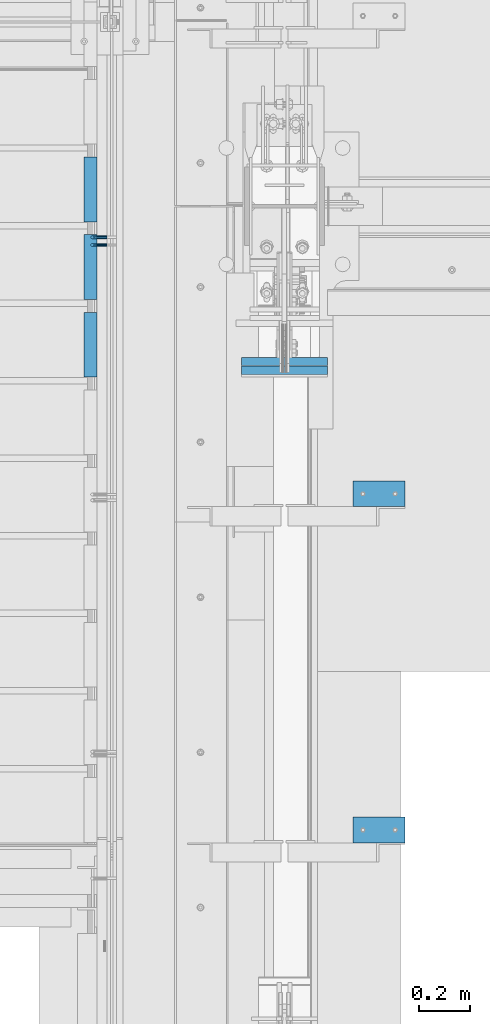
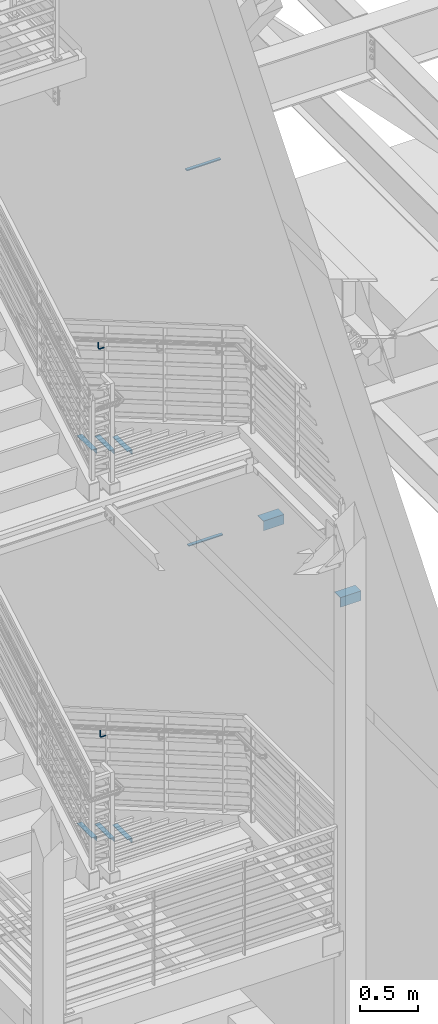
# One storey, part 869 of 1179: 12 beams, 8 elements without a shape of their own.
"""IFC2X3 building model written with IfcOpenShell, lengths in millimetres."""

from ifc_helpers import new_model, si_unit, frame, origin_with_axes, place, context, subcontext, project, spatial, faceted_brep, material, type_object, element, aggregate, save


model = new_model("IFC2X3")

# Units and contexts
model_context = context("Model", 3, precision=1e-05, world=origin_with_axes())
body_context = subcontext(model_context, "Body", "Model", "MODEL_VIEW")
ifc_project = project(units=[si_unit("LENGTHUNIT", "METRE", prefix="MILLI"), si_unit("AREAUNIT", "SQUARE_METRE"), si_unit("VOLUMEUNIT", "CUBIC_METRE"), si_unit("MASSUNIT", "GRAM", prefix="KILO"), si_unit("TIMEUNIT", "SECOND"), si_unit("PLANEANGLEUNIT", "RADIAN"), si_unit("SOLIDANGLEUNIT", "STERADIAN"), si_unit("THERMODYNAMICTEMPERATUREUNIT", "DEGREE_CELSIUS"), si_unit("LUMINOUSINTENSITYUNIT", "LUMEN")], contexts=[model_context])

# Site, building, storey
site_placement = place(None, origin_with_axes())
site = spatial("IfcSite", under=ifc_project, at=site_placement, CompositionType="ELEMENT")
building_placement = place(site_placement, origin_with_axes())
building = spatial("IfcBuilding", under=site, at=building_placement, Name="Undefined", CompositionType="ELEMENT")
storey_placement = place(building_placement, origin_with_axes())
storey = spatial("IfcBuildingStorey", under=building, at=storey_placement, Name="Undefined", CompositionType="ELEMENT", Elevation=0.0)

# Assembly, beams
assembly_1_placement = place(storey_placement, origin_with_axes())
assembly_1 = element("IfcElementAssembly", 1, at=assembly_1_placement, inside=storey, Name="STRINGER", AssemblyPlace="NOTDEFINED", PredefinedType="RIGID_FRAME")
ifc_material_1 = material(Name="STEEL/A36")
beam_type_1 = type_object("IfcBeamType", Name="L2X2X3/16", PredefinedType="NOTDEFINED")
beam_1_placement = place(assembly_1_placement, frame((-330.199999991041, 33974.7356224256, 4867.27499923135), z_axis=(-1.0, 0.0, 0.0), x_axis=(0.0, -1.0, 0.0)))
beam_1 = element("IfcBeam", 2, at=beam_1_placement, type_object=beam_type_1, material=ifc_material_1, Name="ANGLE", ObjectType="L2X2X3/16", context=body_context, shape_type="Brep", body=[
    faceted_brep([(0.0, 25.3999999999996, -25.4000000000015), (0.0, 25.3999999999996, 25.4000000000015), (254.0, 25.3999999999996, 25.4000000000001), (254.0, 25.3999999999996, -25.4000000000001), (0.0, 20.6374999999998, 25.4000000000015), (254.0, 20.6374999999998, 25.4000000000001), (0.0, 20.6374999999998, -20.6374999999971), (254.0, 20.6374999999998, -20.6374999999998), (0.0, -25.3999999999996, -20.6374999999971), (254.0, -25.3999999999996, -20.6374999999998), (0.0, -25.3999999999996, -25.4000000000015), (254.0, -25.3999999999996, -25.4000000000001)], [[[0, 1, 2, 3]], [[1, 4, 5, 2]], [[4, 6, 7, 5]], [[6, 8, 9, 7]], [[8, 10, 11, 9]], [[10, 0, 3, 11]], [[5, 7, 9, 11, 3, 2]], [[10, 8, 6, 4, 1, 0]]]),
])
beam_2_placement = place(assembly_1_placement, frame((-330.199999993097, 34279.5356223616, 4689.47499912165), z_axis=(-1.0, 0.0, 0.0), x_axis=(0.0, -1.0, 0.0)))
beam_2 = element("IfcBeam", 3, at=beam_2_placement, type_object=beam_type_1, material=ifc_material_1, Name="ANGLE", ObjectType="L2X2X3/16", context=body_context, shape_type="Brep", body=[
    faceted_brep([(0.0, 25.3999999999996, -25.4000000000015), (0.0, 25.3999999999996, 25.4000000000015), (254.0, 25.3999999999996, 25.4000000000001), (254.0, 25.3999999999996, -25.4000000000001), (0.0, 20.6374999999998, 25.4000000000015), (254.0, 20.6374999999998, 25.4000000000001), (0.0, 20.6374999999998, -20.6374999999971), (254.0, 20.6374999999998, -20.6374999999998), (0.0, -25.3999999999996, -20.6374999999971), (254.0, -25.3999999999996, -20.6374999999998), (0.0, -25.3999999999996, -25.4000000000015), (254.0, -25.3999999999996, -25.4000000000001)], [[[0, 1, 2, 3]], [[1, 4, 5, 2]], [[4, 6, 7, 5]], [[6, 8, 9, 7]], [[8, 10, 11, 9]], [[10, 0, 3, 11]], [[5, 7, 9, 11, 3, 2]], [[10, 8, 6, 4, 1, 0]]]),
])
beam_3_placement = place(assembly_1_placement, frame((-330.199999995153, 34584.3356222976, 4511.67499901195), z_axis=(-1.0, 0.0, 0.0), x_axis=(0.0, -1.0, 0.0)))
beam_3 = element("IfcBeam", 4, at=beam_3_placement, type_object=beam_type_1, material=ifc_material_1, Name="ANGLE", ObjectType="L2X2X3/16", context=body_context, shape_type="Brep", body=[
    faceted_brep([(0.0, 25.3999999999996, -25.4000000000015), (0.0, 25.3999999999996, 25.4000000000015), (254.0, 25.3999999999996, 25.4000000000001), (254.0, 25.3999999999996, -25.4000000000001), (0.0, 20.6374999999998, 25.4000000000015), (254.0, 20.6374999999998, 25.4000000000001), (0.0, 20.6374999999998, -20.6374999999971), (254.0, 20.6374999999998, -20.6374999999998), (0.0, -25.3999999999996, -20.6374999999971), (254.0, -25.3999999999996, -20.6374999999998), (0.0, -25.3999999999996, -25.4000000000015), (254.0, -25.3999999999996, -25.4000000000001)], [[[0, 1, 2, 3]], [[1, 4, 5, 2]], [[4, 6, 7, 5]], [[6, 8, 9, 7]], [[8, 10, 11, 9]], [[10, 0, 3, 11]], [[5, 7, 9, 11, 3, 2]], [[10, 8, 6, 4, 1, 0]]]),
])
aggregate(assembly_1, [beam_1, beam_2, beam_3])

assembly_2_placement = place(storey_placement, origin_with_axes())
assembly_2 = element("IfcElementAssembly", 5, at=assembly_2_placement, inside=storey, Name="STRINGER", AssemblyPlace="NOTDEFINED", PredefinedType="RIGID_FRAME")
beam_4_placement = place(assembly_2_placement, frame((-330.200000005332, 33974.6819391909, 803.029659879628), z_axis=(-1.0, 0.0, 0.0), x_axis=(0.0, -1.0, 0.0)))
beam_4 = element("IfcBeam", 6, at=beam_4_placement, type_object=beam_type_1, material=ifc_material_1, Name="ANGLE", ObjectType="L2X2X3/16", context=body_context, shape_type="Brep", body=[
    faceted_brep([(0.0, 25.3999999999996, -25.4000000000015), (0.0, 25.3999999999996, 25.4000000000015), (254.0, 25.3999999999996, 25.4000000000001), (254.0, 25.3999999999996, -25.4000000000001), (0.0, 20.6374999999998, 25.4000000000015), (254.0, 20.6374999999998, 25.4000000000001), (0.0, 20.6374999999998, -20.6374999999971), (254.0, 20.6374999999998, -20.6374999999998), (0.0, -25.3999999999996, -20.6374999999971), (254.0, -25.3999999999996, -20.6374999999998), (0.0, -25.3999999999996, -25.4000000000015), (254.0, -25.3999999999996, -25.4000000000001)], [[[0, 1, 2, 3]], [[1, 4, 5, 2]], [[4, 6, 7, 5]], [[6, 8, 9, 7]], [[8, 10, 11, 9]], [[10, 0, 3, 11]], [[5, 7, 9, 11, 3, 2]], [[10, 8, 6, 4, 1, 0]]]),
])
beam_5_placement = place(assembly_2_placement, frame((-330.200000005292, 34279.482092925, 626.547765742485), z_axis=(-1.0, 0.0, 0.0), x_axis=(0.0, -1.0, 0.0)))
beam_5 = element("IfcBeam", 7, at=beam_5_placement, type_object=beam_type_1, material=ifc_material_1, Name="ANGLE", ObjectType="L2X2X3/16", context=body_context, shape_type="Brep", body=[
    faceted_brep([(0.0, 25.3999999999996, -25.4000000000015), (0.0, 25.3999999999996, 25.4000000000015), (254.0, 25.3999999999996, 25.4000000000001), (254.0, 25.3999999999996, -25.4000000000001), (0.0, 20.6374999999998, 25.4000000000015), (254.0, 20.6374999999998, 25.4000000000001), (0.0, 20.6374999999998, -20.6374999999971), (254.0, 20.6374999999998, -20.6374999999998), (0.0, -25.3999999999996, -20.6374999999971), (254.0, -25.3999999999996, -20.6374999999998), (0.0, -25.3999999999996, -25.4000000000015), (254.0, -25.3999999999996, -25.4000000000001)], [[[0, 1, 2, 3]], [[1, 4, 5, 2]], [[4, 6, 7, 5]], [[6, 8, 9, 7]], [[8, 10, 11, 9]], [[10, 0, 3, 11]], [[5, 7, 9, 11, 3, 2]], [[10, 8, 6, 4, 1, 0]]]),
])
beam_6_placement = place(assembly_2_placement, frame((-330.200000005252, 34584.2822466591, 450.065871605343), z_axis=(-1.0, 0.0, 0.0), x_axis=(0.0, -1.0, 0.0)))
beam_6 = element("IfcBeam", 8, at=beam_6_placement, type_object=beam_type_1, material=ifc_material_1, Name="ANGLE", ObjectType="L2X2X3/16", context=body_context, shape_type="Brep", body=[
    faceted_brep([(0.0, 25.3999999999996, -25.4000000000015), (0.0, 25.3999999999996, 25.4000000000015), (254.0, 25.3999999999996, 25.4000000000001), (254.0, 25.3999999999996, -25.4000000000001), (0.0, 20.6374999999998, 25.4000000000015), (254.0, 20.6374999999998, 25.4000000000001), (0.0, 20.6374999999998, -20.6374999999971), (254.0, 20.6374999999998, -20.6374999999998), (0.0, -25.3999999999996, -20.6374999999971), (254.0, -25.3999999999996, -20.6374999999998), (0.0, -25.3999999999996, -25.4000000000015), (254.0, -25.3999999999996, -25.4000000000001)], [[[0, 1, 2, 3]], [[1, 4, 5, 2]], [[4, 6, 7, 5]], [[6, 8, 9, 7]], [[8, 10, 11, 9]], [[10, 0, 3, 11]], [[5, 7, 9, 11, 3, 2]], [[10, 8, 6, 4, 1, 0]]]),
])
aggregate(assembly_2, [beam_4, beam_5, beam_6])

# Assembly, beam
assembly_3_placement = place(storey_placement, origin_with_axes())
assembly_3 = element("IfcElementAssembly", 9, at=assembly_3_placement, inside=storey, Name="GUARDRAIL", AssemblyPlace="NOTDEFINED", PredefinedType="RIGID_FRAME")
beam_type_2 = type_object("IfcBeamType", PredefinedType="NOTDEFINED")
beam_7_placement = place(assembly_3_placement, frame((-266.699999255495, 34269.6796629691, 5619.0742745199), z_axis=(0.0, 0.0, 1.0), x_axis=(-1.0, 0.0, 0.0)))
beam_7 = element("IfcBeam", 10, at=beam_7_placement, type_object=beam_type_2, material=ifc_material_1, Name="BRACKET", context=body_context, shape_type="Brep", body=[
    faceted_brep([(0.0, -4.49012806053361, 4.49012806053452), (0.0, 0.0, 6.34999999999991), (0.0, 4.49012806053361, 4.49012806053452), (0.0, 6.34999999999854, 0.0), (0.0, 4.49012806053361, -4.49012806053452), (0.0, 0.0, -6.34999999999991), (0.0, -4.49012806053361, -4.49012806053452), (0.0, -6.34999999999854, 0.0), (44.4500031699827, 0.0, -6.34999999999991), (44.4500031699827, -4.49012806053361, -4.49012806053452), (44.4500031699827, -6.34999999999854, 2.19733919948339e-09), (44.4500031699827, -4.49012806053361, 4.49012806053452), (44.4500031699827, 0.0, 6.34999999999991), (44.4500031699827, 4.49012806053361, 4.49012806053452), (44.4500031699827, 6.34999999999854, 0.0), (44.4500031699827, 4.49012806053361, -4.49012806053452), (53.0450671075391, 4.4901280570557, -2.18708762112465), (53.97500307462, -4.32919478043914e-09, -3.79778396764459), (53.0450671022344, -4.49012806401151, -2.1870876194389), (50.8000030708674, -6.35000000142099, 1.70147734757802), (48.5549390416977, -4.4901280599006, 5.59004231389645), (47.6250030746168, 1.48793333210051e-09, 7.20073866041594), (48.5549390470023, 4.49012806117025, 5.5900423122107), (50.8000030783693, 6.34999999857973, 1.70147734519378), (55.4485256393576, 6.34999999469437, 6.34999990618098), (59.337090604122, 4.49012805180246, 4.10493587545716), (51.5599606707875, 4.49012805866005, 8.59506393599531), (49.9492643188311, -4.54747350886464e-10, 9.52499990463002), (51.5599606615996, -4.4901280624108, 8.59506393379797), (55.4485256263639, -6.35000000530636, 6.34999990307369), (59.337090594938, -4.49012806926839, 4.10493587326664), (60.9477869468905, -1.0153598850593e-08, 3.17499990462466), (61.6401310450869, 4.49012804462109, 12.6999998130159), (63.5000029792477, -1.81098585017025e-08, 12.6999998092651), (57.1500029867496, 6.3499999893902, 12.6999998145698), (52.6598749240178, 4.49012805522943, 12.6999998130159), (50.8000029792477, -3.10683390125632e-09, 12.6999998092651), (52.6598749134085, -4.49012806583778, 12.6999998055144), (57.1500029739432, -6.35000001061053, 12.6999998039605), (61.6401310344776, -4.49012807644976, 12.6999998055144), (63.5000029792478, -6.94672053214163e-08, 76.1999999999989), (61.6401294880352, -4.49012904147821, 73.5807586715764), (57.1500014109847, -6.35000090467656, 72.4958334126568), (52.6598733669657, -4.49012891602615, 73.5807587357776), (50.8000029792478, -5.78438630327582e-08, 76.1999999999989), (52.6598734909962, 4.49012713825505, 78.8192414384375), (57.1500015765077, 6.34999900287221, 79.9041666981866), (61.6401296120657, 4.49012701564061, 78.8192413758952)], [[[0, 1, 2, 3, 4, 5, 6, 7]], [[6, 5, 8, 9]], [[7, 6, 9, 10]], [[0, 7, 10, 11]], [[1, 0, 11, 12]], [[2, 1, 12, 13]], [[3, 2, 13, 14]], [[4, 3, 14, 15]], [[5, 4, 15, 8]], [[8, 15, 16, 17]], [[9, 8, 17, 18]], [[10, 9, 18, 19]], [[11, 10, 19, 20]], [[12, 11, 20, 21]], [[13, 12, 21, 22]], [[14, 13, 22, 23]], [[15, 14, 23, 16]], [[23, 24, 25, 16]], [[22, 26, 24, 23]], [[21, 27, 26, 22]], [[20, 28, 27, 21]], [[19, 29, 28, 20]], [[18, 30, 29, 19]], [[17, 31, 30, 18]], [[16, 25, 31, 17]], [[25, 32, 33, 31]], [[24, 34, 32, 25]], [[26, 35, 34, 24]], [[27, 36, 35, 26]], [[28, 37, 36, 27]], [[29, 38, 37, 28]], [[30, 39, 38, 29]], [[31, 33, 39, 30]], [[39, 33, 40, 41]], [[38, 39, 41, 42]], [[37, 38, 42, 43]], [[36, 37, 43, 44]], [[35, 36, 44, 45]], [[34, 35, 45, 46]], [[32, 34, 46, 47]], [[33, 32, 47, 40]], [[46, 45, 44, 43, 42, 41, 40, 47]]]),
])
aggregate(assembly_3, [beam_7])

assembly_4_placement = place(storey_placement, origin_with_axes())
assembly_4 = element("IfcElementAssembly", 11, at=assembly_4_placement, inside=storey, Name="GUARDRAIL", AssemblyPlace="NOTDEFINED", PredefinedType="RIGID_FRAME")
beam_8_placement = place(assembly_4_placement, frame((-266.699999255495, 34239.2000011132, 1573.58448032774), z_axis=(0.0, 0.0, 1.0), x_axis=(-1.0, 0.0, 0.0)))
beam_8 = element("IfcBeam", 12, at=beam_8_placement, type_object=beam_type_2, material=ifc_material_1, Name="BRACKET", context=body_context, shape_type="Brep", body=[
    faceted_brep([(0.0, -4.49012806053361, 4.49012806053452), (0.0, 0.0, 6.34999999999991), (0.0, 4.49012806053361, 4.49012806053452), (0.0, 6.34999999999854, 0.0), (0.0, 4.49012806053361, -4.49012806053452), (0.0, 0.0, -6.34999999999991), (0.0, -4.49012806053361, -4.49012806053452), (0.0, -6.34999999999854, 0.0), (44.4500031699827, 0.0, -6.34999999999991), (44.4500031699827, -4.49012806053361, -4.49012806053452), (44.4500031699827, -6.34999999999854, 2.19733919948339e-09), (44.4500031699827, -4.49012806053361, 4.49012806053452), (44.4500031699827, 0.0, 6.34999999999991), (44.4500031699827, 4.49012806053361, 4.49012806053452), (44.4500031699827, 6.34999999999854, 0.0), (44.4500031699827, 4.49012806053361, -4.49012806053452), (53.0450671075391, 4.4901280570557, -2.18708762112465), (53.97500307462, -4.32919478043914e-09, -3.79778396764459), (53.0450671022344, -4.49012806401151, -2.1870876194389), (50.8000030708674, -6.35000000142099, 1.70147734757802), (48.5549390416977, -4.4901280599006, 5.59004231389645), (47.6250030746168, 1.48793333210051e-09, 7.20073866041594), (48.5549390470023, 4.49012806117025, 5.5900423122107), (50.8000030783693, 6.34999999857973, 1.70147734519378), (55.4485256393576, 6.34999999469437, 6.34999990618098), (59.337090604122, 4.49012805180246, 4.10493587545716), (51.5599606707875, 4.49012805866005, 8.59506393599531), (49.9492643188311, -4.54747350886464e-10, 9.52499990463002), (51.5599606615996, -4.4901280624108, 8.59506393379797), (55.4485256263639, -6.35000000530636, 6.34999990307369), (59.337090594938, -4.49012806926839, 4.10493587326664), (60.9477869468905, -1.0153598850593e-08, 3.17499990462466), (61.6401310450869, 4.49012804462109, 12.6999998130159), (63.5000029792477, -1.81098585017025e-08, 12.6999998092651), (57.1500029867496, 6.3499999893902, 12.6999998145698), (52.6598749240178, 4.49012805522943, 12.6999998130159), (50.8000029792477, -3.10683390125632e-09, 12.6999998092651), (52.6598749134085, -4.49012806583778, 12.6999998055144), (57.1500029739432, -6.35000001061053, 12.6999998039605), (61.6401310344776, -4.49012807644976, 12.6999998055144), (63.5000029792478, -6.94672053214163e-08, 76.1999999999989), (61.6401296086745, -4.49012715444769, 73.6001774342253), (57.1500015634042, -6.3499991642384, 72.5232956440923), (52.6598734876054, -4.49012727027366, 73.6001773671605), (50.8000029792478, -5.78438630327582e-08, 76.1999999999989), (52.6598733730815, 4.4901289120171, 78.79982245163), (57.150001410549, 6.35000092050541, 79.8767042410086), (61.6401294941506, 4.49012902523828, 78.7998225171859)], [[[0, 1, 2, 3, 4, 5, 6, 7]], [[6, 5, 8, 9]], [[7, 6, 9, 10]], [[0, 7, 10, 11]], [[1, 0, 11, 12]], [[2, 1, 12, 13]], [[3, 2, 13, 14]], [[4, 3, 14, 15]], [[5, 4, 15, 8]], [[8, 15, 16, 17]], [[9, 8, 17, 18]], [[10, 9, 18, 19]], [[11, 10, 19, 20]], [[12, 11, 20, 21]], [[13, 12, 21, 22]], [[14, 13, 22, 23]], [[15, 14, 23, 16]], [[23, 24, 25, 16]], [[22, 26, 24, 23]], [[21, 27, 26, 22]], [[20, 28, 27, 21]], [[19, 29, 28, 20]], [[18, 30, 29, 19]], [[17, 31, 30, 18]], [[16, 25, 31, 17]], [[25, 32, 33, 31]], [[24, 34, 32, 25]], [[26, 35, 34, 24]], [[27, 36, 35, 26]], [[28, 37, 36, 27]], [[29, 38, 37, 28]], [[30, 39, 38, 29]], [[31, 33, 39, 30]], [[39, 33, 40, 41]], [[38, 39, 41, 42]], [[37, 38, 42, 43]], [[36, 37, 43, 44]], [[35, 36, 44, 45]], [[34, 35, 45, 46]], [[32, 34, 46, 47]], [[33, 32, 47, 40]], [[46, 45, 44, 43, 42, 41, 40, 47]]]),
])
aggregate(assembly_4, [beam_8])

assembly_5_placement = place(storey_placement, origin_with_axes())
assembly_5 = element("IfcElementAssembly", 13, at=assembly_5_placement, inside=storey, Name="BEAM", AssemblyPlace="NOTDEFINED", PredefinedType="RIGID_FRAME")
ifc_material_2 = material(Name="STEEL/A572-GR.50")
beam_type_3 = type_object("IfcBeamType", PredefinedType="NOTDEFINED")
beam_9_placement = place(assembly_5_placement, frame((431.80003662088, 33765.1528914681, 7589.8375), z_axis=(-1.0, 0.0, 0.0), x_axis=(0.0, 1.0, 0.0)))
beam_9 = element("IfcBeam", 14, at=beam_9_placement, type_object=beam_type_3, material=ifc_material_2, Name="PLATE", context=body_context, shape_type="Brep", body=[
    faceted_brep([(0.0, 4.76249999999982, -168.275000000001), (0.0, 4.76250000000073, 168.275), (31.75, 4.76249999999982, 168.275000000001), (31.75, 4.76249999999982, -168.275000000001), (0.0, -4.76250000000073, 168.275), (31.75, -4.76249999999982, 168.275000000001), (0.0, -4.76249999999982, -168.275000000001), (31.75, -4.76249999999982, -168.275000000001)], [[[0, 1, 2, 3]], [[1, 4, 5, 2]], [[4, 6, 7, 5]], [[6, 0, 3, 7]], [[5, 7, 3, 2]], [[6, 4, 1, 0]]]),
])
aggregate(assembly_5, [beam_9])

assembly_6_placement = place(storey_placement, origin_with_axes())
assembly_6 = element("IfcElementAssembly", 15, at=assembly_6_placement, inside=storey, Name="BEAM", AssemblyPlace="NOTDEFINED", PredefinedType="RIGID_FRAME")
beam_10_placement = place(assembly_6_placement, frame((431.800036620873, 33730.9790964075, 3678.2375), z_axis=(-1.0, 0.0, 0.0), x_axis=(0.0, 1.0, 0.0)))
beam_10 = element("IfcBeam", 16, at=beam_10_placement, type_object=beam_type_3, material=ifc_material_2, Name="PLATE", context=body_context, shape_type="Brep", body=[
    faceted_brep([(0.0, 4.76249999999982, -168.275000000001), (0.0, 4.76250000000073, 168.275), (31.75, 4.76249999999982, 168.275000000001), (31.75, 4.76249999999982, -168.275000000001), (0.0, -4.76250000000073, 168.275), (31.75, -4.76249999999982, 168.275000000001), (0.0, -4.76249999999982, -168.275000000001), (31.75, -4.76249999999982, -168.275000000001)], [[[0, 1, 2, 3]], [[1, 4, 5, 2]], [[4, 6, 7, 5]], [[6, 0, 3, 7]], [[5, 7, 3, 2]], [[6, 4, 1, 0]]]),
])
aggregate(assembly_6, [beam_10])

assembly_7_placement = place(storey_placement, origin_with_axes())
assembly_7 = element("IfcElementAssembly", 17, at=assembly_7_placement, inside=storey, Name="ANGLE", AssemblyPlace="NOTDEFINED", PredefinedType="RIGID_FRAME")
beam_type_4 = type_object("IfcBeamType", Name="L4X4X1/4", PredefinedType="NOTDEFINED")
beam_11_placement = place(assembly_7_placement, frame((701.596355341565, 33261.3, 4051.3), z_axis=(0.0, 0.0, -1.0), x_axis=(1.0, 0.0, 0.0)))
beam_11 = element("IfcBeam", 18, at=beam_11_placement, type_object=beam_type_4, material=ifc_material_1, Name="ANGLE", ObjectType="L4X4X1/4", context=body_context, shape_type="Brep", body=[
    faceted_brep([(1.90993887372315e-11, 50.8000000000002, -50.8000000000002), (1.90993887372315e-11, 50.8000000000002, 50.8000000000002), (203.200000000001, 50.7999999999993, 50.8000000000002), (203.200000000001, 50.7999999999993, -50.8000000000002), (0.0, 44.4500000000007, 50.8000000000002), (203.200000000001, 44.4500000000007, 50.8000000000002), (0.0, 44.4500000000007, -44.4499999999998), (203.200000000001, 44.4500000000007, -44.4499999999998), (0.0, -50.7999999999993, -44.4499999999998), (203.200000000001, -50.7999999999993, -44.4499999999998), (-1.81898940354586e-11, -50.7999999999997, -50.8000000000002), (203.200000000001, -50.7999999999993, -50.8000000000002)], [[[0, 1, 2, 3]], [[1, 4, 5, 2]], [[4, 6, 7, 5]], [[6, 8, 9, 7]], [[8, 10, 11, 9]], [[10, 0, 3, 11]], [[5, 7, 9, 11, 3, 2]], [[10, 8, 6, 4, 1, 0]]]),
])
aggregate(assembly_7, [beam_11])

assembly_8_placement = place(storey_placement, origin_with_axes())
assembly_8 = element("IfcElementAssembly", 19, at=assembly_8_placement, inside=storey, Name="ANGLE", AssemblyPlace="NOTDEFINED", PredefinedType="RIGID_FRAME")
beam_12_placement = place(assembly_8_placement, frame((701.596355341565, 31940.5, 4051.3), z_axis=(0.0, 0.0, -1.0), x_axis=(1.0, 0.0, 0.0)))
beam_12 = element("IfcBeam", 20, at=beam_12_placement, type_object=beam_type_4, material=ifc_material_1, Name="ANGLE", ObjectType="L4X4X1/4", context=body_context, shape_type="Brep", body=[
    faceted_brep([(1.90993887372315e-11, 50.8000000000002, -50.8000000000002), (1.90993887372315e-11, 50.8000000000002, 50.8000000000002), (203.200000000001, 50.7999999999993, 50.8000000000002), (203.200000000001, 50.7999999999993, -50.8000000000002), (0.0, 44.4500000000007, 50.8000000000002), (203.200000000001, 44.4500000000007, 50.8000000000002), (0.0, 44.4500000000007, -44.4499999999998), (203.200000000001, 44.4500000000007, -44.4499999999998), (0.0, -50.7999999999993, -44.4499999999998), (203.200000000001, -50.7999999999993, -44.4499999999998), (-1.81898940354586e-11, -50.7999999999997, -50.8000000000002), (203.200000000001, -50.7999999999993, -50.8000000000002)], [[[0, 1, 2, 3]], [[1, 4, 5, 2]], [[4, 6, 7, 5]], [[6, 8, 9, 7]], [[8, 10, 11, 9]], [[10, 0, 3, 11]], [[5, 7, 9, 11, 3, 2]], [[10, 8, 6, 4, 1, 0]]]),
])
aggregate(assembly_8, [beam_12])

save(model, "model.ifc")
